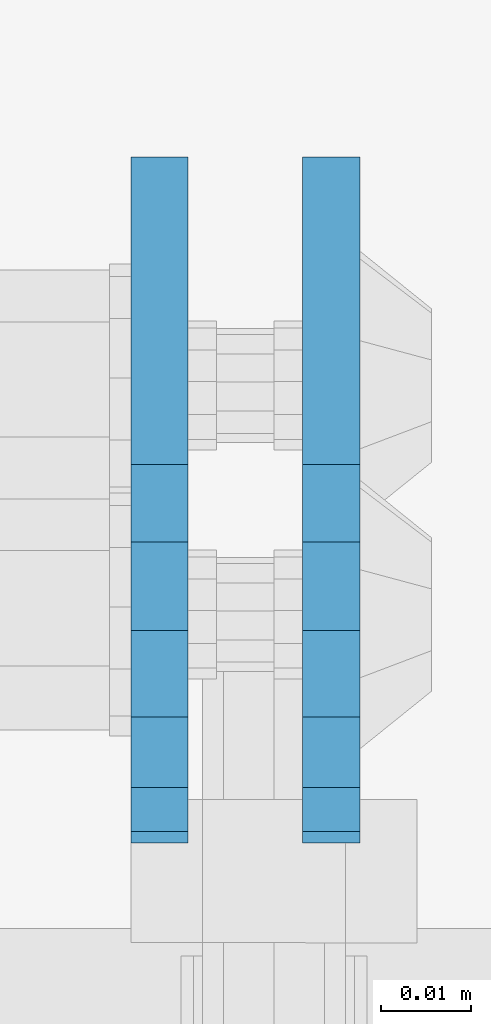
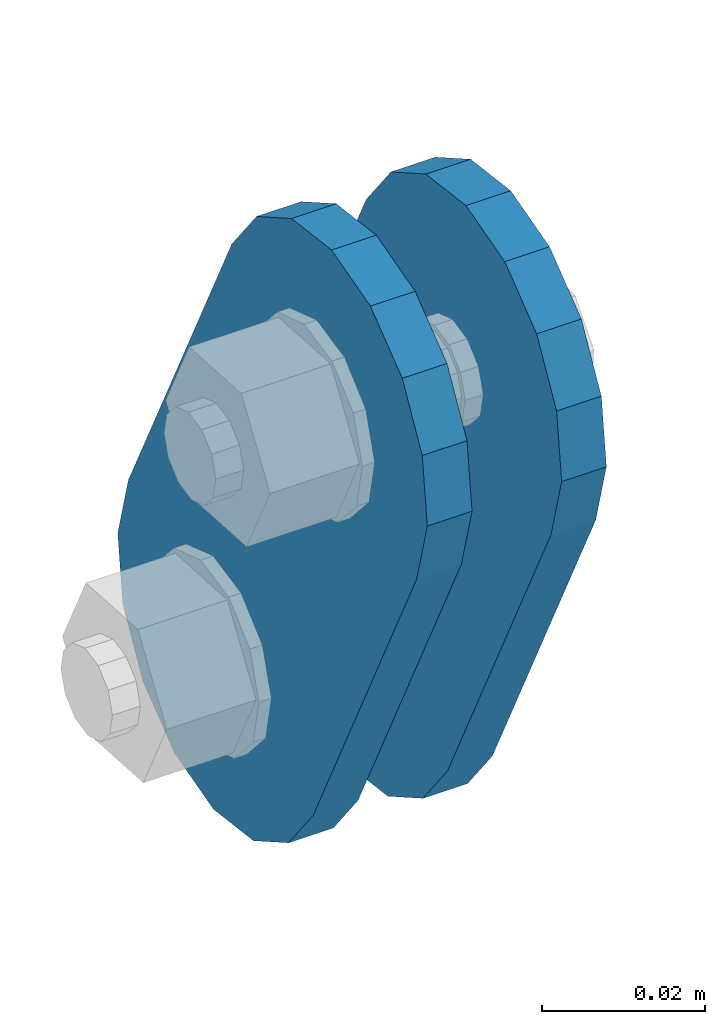
# One storey, part 1834 of 1876: 2 plates, 2 elements without a shape of their own.
"""IFC2X3 building model written with IfcOpenShell, lengths in millimetres."""

import ifcopenshell
import ifcopenshell.guid

model = None  # the IFC model being written
_history = None  # IfcOwnerHistory: only IFC2X3 demands one
_inside = {}  # id of a spatial element -> (the spatial element, [elements in it])
_under = {}  # id of a project, library or spatial element -> (it, [spatial elements below it])
_declared = {}  # id of a project -> (the project, [libraries it declares])
_typed = {}  # id of a type object -> (the type object, [elements of that type])
_made_of = {}  # id of a material, layer set ... -> (it, [elements and type objects made of it])


def new_model(schema):
    """Start an empty IFC model of exactly this schema.

    Asked for "IFC4X3", IfcOpenShell would pick the latest addendum, in which some entities
    have other attributes; the version numbers below select the first issue.
    IFC2X3 requires an IfcOwnerHistory on every rooted entity: one is made here for all.
    """
    global model, _history
    if schema == "IFC4X3":
        model = ifcopenshell.file(schema_version=(4, 3, 0, 0))
    else:
        model = ifcopenshell.file(schema=schema)
    _inside.clear()
    _under.clear()
    _declared.clear()
    _typed.clear()
    _made_of.clear()
    _history = None
    if model.schema == "IFC2X3":
        org = make("IfcOrganization", Name="unknown")
        user = make(
            "IfcPersonAndOrganization",
            ThePerson=make("IfcPerson", FamilyName="unknown"),
            TheOrganization=org,
        )
        app = make(
            "IfcApplication",
            ApplicationDeveloper=org,
            Version="unknown",
            ApplicationFullName="unknown",
            ApplicationIdentifier="unknown",
        )
        _history = make(
            "IfcOwnerHistory",
            OwningUser=user,
            OwningApplication=app,
            ChangeAction="ADDED",
            CreationDate=0,
        )
    return model


def make(cls, **values):
    """One entity of the class cls with the attributes given. An attribute that is None is left unset."""
    return model.create_entity(
        cls, **{name: value for name, value in values.items() if value is not None}
    )


def rooted(cls, **values):
    """An entity with a GlobalId (a new one), such as an element, a storey or a relation."""
    return make(cls, GlobalId=ifcopenshell.guid.new(), OwnerHistory=_history, **values)


def si_unit(unit_type, name, prefix=None):
    """IfcSIUnit, for example si_unit("LENGTHUNIT", "METRE", prefix="MILLI")."""
    return make("IfcSIUnit", UnitType=unit_type, Prefix=prefix, Name=name)


def assignment(units):
    """IfcUnitAssignment: the units of a project."""
    return None if units is None else make("IfcUnitAssignment", Units=units)


def point(xyz):
    """IfcCartesianPoint."""
    return None if xyz is None else make("IfcCartesianPoint", Coordinates=xyz)


def direction(xyz):
    """IfcDirection."""
    return None if xyz is None else make("IfcDirection", DirectionRatios=xyz)


def frame(location, z_axis=None, x_axis=None):
    """IfcAxis2Placement3D, a coordinate frame: its origin and axes. An axis left out is left unset."""
    return make(
        "IfcAxis2Placement3D",
        Location=point(location),
        Axis=direction(z_axis),
        RefDirection=direction(x_axis),
    )


def origin_with_axes():
    """The frame at (0, 0, 0) with the z axis (0, 0, 1) and the x axis (1, 0, 0) written out."""
    return frame((0.0, 0.0, 0.0), z_axis=(0.0, 0.0, 1.0), x_axis=(1.0, 0.0, 0.0))


def place(relative_to, where):
    """IfcLocalPlacement: puts the frame where relative to a parent placement (None: the world)."""
    return make(
        "IfcLocalPlacement", PlacementRelTo=relative_to, RelativePlacement=where
    )


def context(
    kind, dimensions, precision=None, world=None, true_north=None, identifier=None
):
    """IfcGeometricRepresentationContext, for example the 3D "Model" context."""
    return make(
        "IfcGeometricRepresentationContext",
        ContextIdentifier=identifier,
        ContextType=kind,
        CoordinateSpaceDimension=dimensions,
        Precision=precision,
        WorldCoordinateSystem=world,
        TrueNorth=true_north,
    )


def subcontext(parent, identifier, kind, view, scale=None):
    """IfcGeometricRepresentationSubContext, for example "Body" below "Model"."""
    return make(
        "IfcGeometricRepresentationSubContext",
        ContextIdentifier=identifier,
        ContextType=kind,
        ParentContext=parent,
        TargetScale=scale,
        TargetView=view,
    )


def project(units=None, contexts=None):
    """IfcProject with its units and contexts."""
    return rooted(
        "IfcProject",
        Name="project",
        RepresentationContexts=contexts,
        UnitsInContext=assignment(units),
    )


def spatial(cls, under=None, at=None, **own):
    """A site, building, storey or space (cls), placed at a placement, below another one or the project."""
    s = rooted(cls, ObjectPlacement=at, **own)
    if under is not None:
        _under.setdefault(under.id(), (under, []))[1].append(s)
    return s


def faces_of(points, faces, orient=None, outer=None):
    """IfcFace entities. A face is a list of loops; a loop is a list of indices into points, from 0.

    orient and outer hold one flag for each loop. By default every Orientation is true, the
    first loop of a face is its IfcFaceOuterBound and the others are IfcFaceBound.
    """
    made = []
    for i, loops in enumerate(faces):
        bounds = []
        for j, loop in enumerate(loops):
            is_outer = j == 0 if outer is None else outer[i][j]
            bounds.append(
                make(
                    "IfcFaceOuterBound" if is_outer else "IfcFaceBound",
                    Bound=make("IfcPolyLoop", Polygon=[points[k] for k in loop]),
                    Orientation=True if orient is None else orient[i][j],
                )
            )
        made.append(make("IfcFace", Bounds=bounds))
    return made


def faceted_brep(points, faces, orient=None, outer=None, voids=None):
    """IfcFacetedBrep: a solid bounded by flat faces; with voids (closed shells), ...WithVoids."""
    shared = [point(p) for p in points]
    hull = make("IfcClosedShell", CfsFaces=faces_of(shared, faces, orient, outer))
    if voids is None:
        return make("IfcFacetedBrep", Outer=hull)
    return make(
        "IfcFacetedBrepWithVoids",
        Outer=hull,
        Voids=[
            make(cls, CfsFaces=faces_of(shared, fs, o, b)) for cls, fs, o, b in voids
        ],
    )


def shape(context_of_items, identifier, shape_type, items):
    """IfcShapeRepresentation: the items that make up one representation, for example the "Body"."""
    return make(
        "IfcShapeRepresentation",
        ContextOfItems=context_of_items,
        RepresentationIdentifier=identifier,
        RepresentationType=shape_type,
        Items=items,
    )


def material(Name=None, Category=None):
    """IfcMaterial."""
    return make("IfcMaterial", Name=Name, Category=Category)


def made_of(thing, what):
    """Note that an element or type object is made of a material, layer set ...; save() writes the relation."""
    if what is not None:
        _made_of.setdefault(what.id(), (what, []))[1].append(thing)
    return thing


def type_object(cls, material=None, **own):
    """A type object (cls), such as IfcWallType, which elements share."""
    return made_of(rooted(cls, **own), material)


def element(
    cls,
    number,
    at=None,
    inside=None,
    cuts=None,
    type_object=None,
    material=None,
    context=None,
    identifier="Body",
    shape_type=None,
    held_by="IfcProductDefinitionShape",
    body=None,
    shapes=None,
    **own,
):
    """One element of the class cls, such as IfcWall. Its Tag is "e" and its number.

    at: its placement. inside: the storey or other place that contains it. cuts: it is an
    opening in that element (IfcRelVoidsElement). A single representation is given by context,
    identifier, shape_type and body (its items); several are given by shapes. held_by: the class
    of the entity that holds the representations. save() writes the other relations.
    """
    e = rooted(cls, Tag="e%d" % number, ObjectPlacement=at, **own)
    if body is not None:
        shapes = [shape(context, identifier, shape_type, body)]
    if shapes is not None:
        e.Representation = make(held_by, Representations=shapes)
    if inside is not None:
        _inside.setdefault(inside.id(), (inside, []))[1].append(e)
    if cuts is not None:
        rooted(
            "IfcRelVoidsElement", RelatingBuildingElement=cuts, RelatedOpeningElement=e
        )
    if type_object is not None:
        _typed.setdefault(type_object.id(), (type_object, []))[1].append(e)
    return made_of(e, material)


def aggregate(whole, parts):
    """IfcRelAggregates: a whole, such as a stair, and the parts it consists of."""
    return rooted("IfcRelAggregates", RelatingObject=whole, RelatedObjects=parts)


def save(model, path):
    """Write the relations noted so far, then the file.

    IfcRelAggregates (storeys below a building ...), IfcRelContainedInSpatialStructure (elements
    in a storey), IfcRelDefinesByType, IfcRelAssociatesMaterial and IfcRelDeclares: one each for
    every whole, place, type object, material and project.
    """
    for whole, parts in _under.values():
        aggregate(whole, parts)
    for where, things in _inside.values():
        rooted(
            "IfcRelContainedInSpatialStructure",
            RelatedElements=things,
            RelatingStructure=where,
        )
    for kind, things in _typed.values():
        rooted("IfcRelDefinesByType", RelatedObjects=things, RelatingType=kind)
    for what, things in _made_of.values():
        rooted("IfcRelAssociatesMaterial", RelatedObjects=things, RelatingMaterial=what)
    for by, libraries in _declared.values():
        rooted("IfcRelDeclares", RelatingContext=by, RelatedDefinitions=libraries)
    model.write(path)


model = new_model("IFC2X3")

# Units and contexts
model_context = context("Model", 3, precision=1e-05, world=origin_with_axes())
body_context = subcontext(model_context, "Body", "Model", "MODEL_VIEW")
ifc_project = project(units=[si_unit("LENGTHUNIT", "METRE", prefix="MILLI"), si_unit("AREAUNIT", "SQUARE_METRE"), si_unit("VOLUMEUNIT", "CUBIC_METRE"), si_unit("MASSUNIT", "GRAM", prefix="KILO"), si_unit("TIMEUNIT", "SECOND"), si_unit("PLANEANGLEUNIT", "RADIAN"), si_unit("SOLIDANGLEUNIT", "STERADIAN"), si_unit("THERMODYNAMICTEMPERATUREUNIT", "DEGREE_CELSIUS"), si_unit("LUMINOUSINTENSITYUNIT", "LUMEN")], contexts=[model_context])

# Site, building, storey
site_placement = place(None, origin_with_axes())
site = spatial("IfcSite", under=ifc_project, at=site_placement, CompositionType="ELEMENT")
building_placement = place(site_placement, origin_with_axes())
building = spatial("IfcBuilding", under=site, at=building_placement, Name="Undefined", CompositionType="ELEMENT")
storey_placement = place(building_placement, origin_with_axes())
storey = spatial("IfcBuildingStorey", under=building, at=storey_placement, Name="Undefined", CompositionType="ELEMENT", Elevation=0.0)

# Assembly, plate
assembly_1_placement = place(storey_placement, origin_with_axes())
assembly_1 = element("IfcElementAssembly", 1, at=assembly_1_placement, inside=storey, Name="PLATE", AssemblyPlace="NOTDEFINED", PredefinedType="RIGID_FRAME")
ifc_material = material(Name="STEEL/A36")
plate_type = type_object("IfcPlateType", PredefinedType="NOTDEFINED")
plate_1_placement = place(assembly_1_placement, frame((5086.36120478435, 14070.1626500628, 17725.177677481), z_axis=(0.0, -0.894427191199917, -0.447213595099956), x_axis=(0.0, 0.447213595099955, -0.894427191199917)))
plate_1 = element("IfcPlate", 2, at=plate_1_placement, type_object=plate_type, material=ifc_material, Name="PLATE", context=body_context, shape_type="Brep", body=[
    faceted_brep([(-8.59611645864788e-07, -3.17499999999654, 25.3999987589127), (1.93345873884391, -3.17499999999382, 35.1201580589886), (1.93345873884391, 3.17500000000564, 35.1201580589886), (-8.59611645864788e-07, 3.17500000000382, 25.3999987589132), (7.43948648259902, -3.17499999999109, 43.3605112870105), (7.43948648259902, 3.17500000000928, 43.3605112870105), (15.6798395242777, -3.17499999998654, 48.8665393096448), (15.6798395242777, 3.17500000001382, 48.8665393096448), (25.3999987589095, -3.17499999998199, 50.7999992370592), (25.3999987589095, 3.17500000001837, 50.7999992370592), (82.196130752618, -3.17499999998381, 50.7999992370605), (82.196130752618, 3.17500000001655, 50.7999992370642), (91.9162897887145, -3.17499999997926, 48.8665393918873), (91.9162897887145, 3.1750000000211, 48.8665393918909), (100.156642725027, -3.17499999997472, 43.3605115909359), (100.156642725027, 3.17500000002565, 43.3605115909395), (105.662670525982, -3.17499999997108, 35.1201586546285), (105.662670525986, 3.17500000002929, 35.1201586546358), (107.596130371159, -3.17499999996744, 25.3999996185757), (107.596130371159, 3.17500000003292, 25.3999996185794), (105.662670525981, -3.17499999996471, 15.6798405824902), (105.662670525981, 3.17500000003565, 15.6798405824939), (100.156642725024, -3.17499999996471, 7.43948764618654), (100.156642725025, 3.17500000003565, 7.43948764619017), (91.9162897887127, -3.17499999996562, 1.93345984522784), (91.9162897887127, 3.17500000003474, 1.93345984523148), (82.196130752618, -3.17499999996835, 4.54747350886464e-11), (82.196130752618, 3.1750000000311, 4.91127138957381e-11), (25.399998758905, -3.17499999999018, -8.64019966684282e-12), (25.399998758905, 3.17500000001019, -8.64019966684282e-12), (15.679839921364, -3.17499999999382, 1.9334597629304), (15.679839921364, 3.17500000000655, 1.9334597629304), (7.43948709043525, -3.17499999999654, 7.43948734220839), (7.43948709043525, 3.17500000000382, 7.43948734220885), (1.93345923228208, -3.17499999999654, 15.6798399868012), (1.93345923228208, 3.17500000000291, 15.6798399868012)], [[[0, 1, 2, 3]], [[1, 4, 5, 2]], [[4, 6, 7, 5]], [[6, 8, 9, 7]], [[8, 10, 11, 9]], [[10, 12, 13, 11]], [[12, 14, 15, 13]], [[14, 16, 17, 15]], [[16, 18, 19, 17]], [[18, 20, 21, 19]], [[20, 22, 23, 21]], [[22, 24, 25, 23]], [[24, 26, 27, 25]], [[26, 28, 29, 27]], [[28, 30, 31, 29]], [[30, 32, 33, 31]], [[32, 34, 35, 33]], [[34, 0, 3, 35]], [[5, 7, 9, 11, 13, 15, 17, 19, 21, 23, 25, 27, 29, 31, 33, 35, 3, 2]], [[34, 32, 30, 28, 26, 24, 22, 20, 18, 16, 14, 12, 10, 8, 6, 4, 1, 0]]]),
])
aggregate(assembly_1, [plate_1])

assembly_2_placement = place(storey_placement, origin_with_axes())
assembly_2 = element("IfcElementAssembly", 3, at=assembly_2_placement, inside=storey, Name="PLATE", AssemblyPlace="NOTDEFINED", PredefinedType="RIGID_FRAME")
plate_2_placement = place(assembly_2_placement, frame((5067.29999999999, 14070.1626500628, 17725.177677481), z_axis=(0.0, -0.894427191199917, -0.447213595099956), x_axis=(0.0, 0.447213595099955, -0.894427191199917)))
plate_2 = element("IfcPlate", 4, at=plate_2_placement, type_object=plate_type, material=ifc_material, Name="PLATE", context=body_context, shape_type="Brep", body=[
    faceted_brep([(-8.59611645864788e-07, -3.17499999999654, 25.3999987589127), (1.93345873884391, -3.17499999999382, 35.1201580589886), (1.93345873884391, 3.17500000000564, 35.1201580589886), (-8.59611645864788e-07, 3.17500000000382, 25.3999987589132), (7.43948648259902, -3.17499999999109, 43.3605112870105), (7.43948648259902, 3.17500000000928, 43.3605112870105), (15.6798395242777, -3.17499999998654, 48.8665393096448), (15.6798395242777, 3.17500000001382, 48.8665393096448), (25.3999987589095, -3.17499999998199, 50.7999992370592), (25.3999987589095, 3.17500000001837, 50.7999992370592), (82.196130752618, -3.17499999998381, 50.7999992370605), (82.196130752618, 3.17500000001655, 50.7999992370642), (91.9162897887145, -3.17499999997926, 48.8665393918873), (91.9162897887145, 3.1750000000211, 48.8665393918909), (100.156642725027, -3.17499999997472, 43.3605115909359), (100.156642725027, 3.17500000002565, 43.3605115909395), (105.662670525982, -3.17499999997108, 35.1201586546285), (105.662670525986, 3.17500000002929, 35.1201586546358), (107.596130371159, -3.17499999996744, 25.3999996185757), (107.596130371159, 3.17500000003292, 25.3999996185794), (105.662670525981, -3.17499999996471, 15.6798405824902), (105.662670525981, 3.17500000003565, 15.6798405824939), (100.156642725024, -3.17499999996471, 7.43948764618654), (100.156642725025, 3.17500000003565, 7.43948764619017), (91.9162897887127, -3.17499999996562, 1.93345984522784), (91.9162897887127, 3.17500000003474, 1.93345984523148), (82.196130752618, -3.17499999996835, 4.54747350886464e-11), (82.196130752618, 3.1750000000311, 4.91127138957381e-11), (25.399998758905, -3.17499999999018, -8.64019966684282e-12), (25.399998758905, 3.17500000001019, -8.64019966684282e-12), (15.679839921364, -3.17499999999382, 1.9334597629304), (15.679839921364, 3.17500000000655, 1.9334597629304), (7.43948709043525, -3.17499999999654, 7.43948734220839), (7.43948709043525, 3.17500000000382, 7.43948734220885), (1.93345923228208, -3.17499999999654, 15.6798399868012), (1.93345923228208, 3.17500000000291, 15.6798399868012)], [[[0, 1, 2, 3]], [[1, 4, 5, 2]], [[4, 6, 7, 5]], [[6, 8, 9, 7]], [[8, 10, 11, 9]], [[10, 12, 13, 11]], [[12, 14, 15, 13]], [[14, 16, 17, 15]], [[16, 18, 19, 17]], [[18, 20, 21, 19]], [[20, 22, 23, 21]], [[22, 24, 25, 23]], [[24, 26, 27, 25]], [[26, 28, 29, 27]], [[28, 30, 31, 29]], [[30, 32, 33, 31]], [[32, 34, 35, 33]], [[34, 0, 3, 35]], [[5, 7, 9, 11, 13, 15, 17, 19, 21, 23, 25, 27, 29, 31, 33, 35, 3, 2]], [[34, 32, 30, 28, 26, 24, 22, 20, 18, 16, 14, 12, 10, 8, 6, 4, 1, 0]]]),
])
aggregate(assembly_2, [plate_2])

save(model, "model.ifc")
